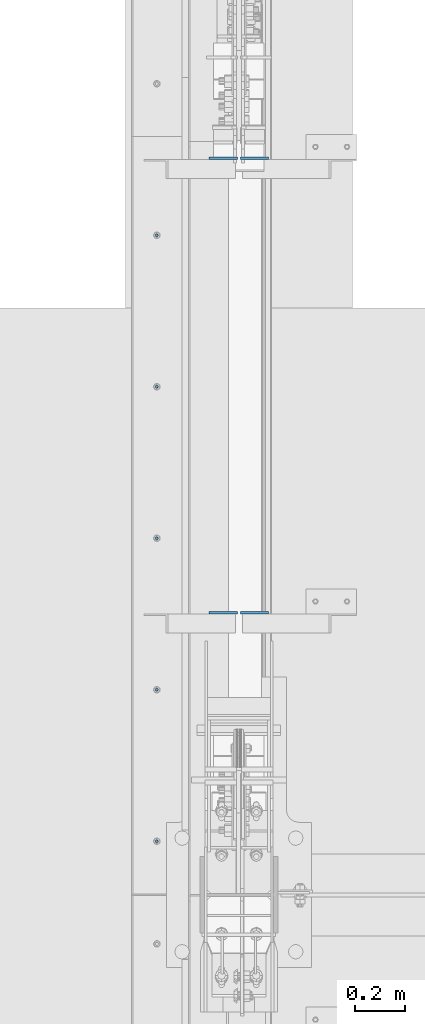
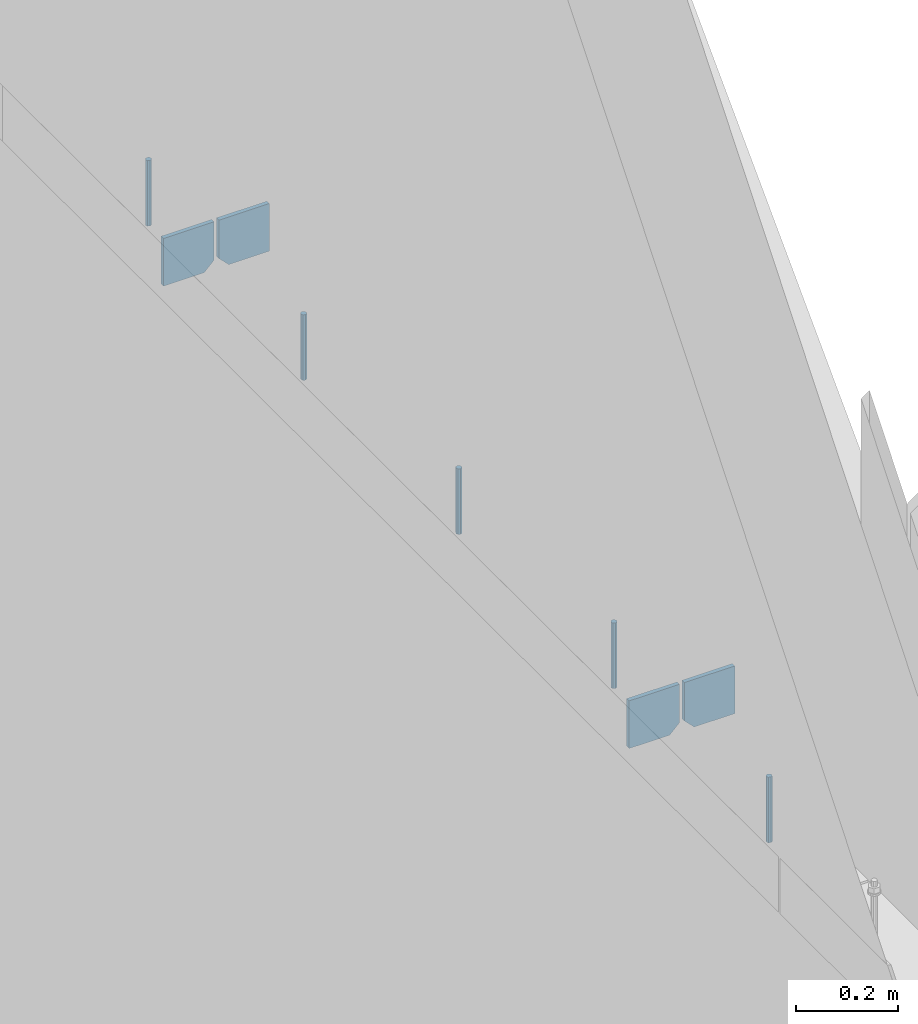
# One storey, part 390 of 1179: 9 columns, 1 element without a shape of its own.
"""IFC2X3 building model written with IfcOpenShell, lengths in millimetres."""

from ifc_helpers import new_model, si_unit, frame, origin_with_axes, place, context, subcontext, project, spatial, faceted_brep, material, type_object, element, aggregate, save


model = new_model("IFC2X3")

# Units and contexts
model_context = context("Model", 3, precision=1e-05, world=origin_with_axes())
body_context = subcontext(model_context, "Body", "Model", "MODEL_VIEW")
ifc_project = project(units=[si_unit("LENGTHUNIT", "METRE", prefix="MILLI"), si_unit("AREAUNIT", "SQUARE_METRE"), si_unit("VOLUMEUNIT", "CUBIC_METRE"), si_unit("MASSUNIT", "GRAM", prefix="KILO"), si_unit("TIMEUNIT", "SECOND"), si_unit("PLANEANGLEUNIT", "RADIAN"), si_unit("SOLIDANGLEUNIT", "STERADIAN"), si_unit("THERMODYNAMICTEMPERATUREUNIT", "DEGREE_CELSIUS"), si_unit("LUMINOUSINTENSITYUNIT", "LUMEN")], contexts=[model_context])

# Site, building, storey
site_placement = place(None, origin_with_axes())
site = spatial("IfcSite", under=ifc_project, at=site_placement, CompositionType="ELEMENT")
building_placement = place(site_placement, origin_with_axes())
building = spatial("IfcBuilding", under=site, at=building_placement, Name="Undefined", CompositionType="ELEMENT")
storey_placement = place(building_placement, origin_with_axes())
storey = spatial("IfcBuildingStorey", under=building, at=storey_placement, Name="Undefined", CompositionType="ELEMENT", Elevation=0.0)

# Assembly, columns
assembly_placement = place(storey_placement, origin_with_axes())
assembly = element("IfcElementAssembly", 1, at=assembly_placement, inside=storey, Name="BEAM", AssemblyPlace="NOTDEFINED", PredefinedType="RIGID_FRAME")
ifc_material_1 = material(Name="STEEL/A36")
column_type_1 = type_object("IfcColumnType", PredefinedType="NOTDEFINED")
column_1_placement = place(assembly_placement, frame((494.506249999998, 12615.8625, 3702.05), z_axis=(-1.0, 0.0, 0.0), x_axis=(0.0, 0.0, 1.0)))
column_1 = element("IfcColumn", 2, at=column_1_placement, type_object=column_type_1, material=ifc_material_1, Name="PLATE", context=body_context, shape_type="Brep", body=[
    faceted_brep([(22.2250000000004, 4.76250000000073, 57.1500000000015), (0.0, 4.76250000000073, 34.9249999999993), (0.0, -4.76250000000073, 34.9249999999993), (22.2250000000004, -4.76250000000073, 57.1500000000015), (114.300000000001, 4.76250000000073, 57.1500000000015), (114.300000000001, 4.76250000000073, -57.1500000000015), (0.0, 4.76250000000073, -57.1500000000015), (114.300000000001, -4.76250000000073, 57.1500000000015), (0.0, -4.76250000000073, -57.1500000000015), (114.300000000001, -4.76250000000073, -57.1500000000015)], [[[0, 1, 2, 3]], [[4, 5, 6, 1, 0]], [[7, 4, 0, 3]], [[8, 9, 7, 3, 2]], [[8, 6, 5, 9]], [[7, 9, 5, 4]], [[6, 8, 2, 1]]]),
])
column_2_placement = place(assembly_placement, frame((369.093750000003, 12615.8625, 3702.05), z_axis=(1.0, 0.0, 0.0), x_axis=(0.0, 0.0, 1.0)))
column_2 = element("IfcColumn", 3, at=column_2_placement, type_object=column_type_1, material=ifc_material_1, Name="PLATE", context=body_context, shape_type="Brep", body=[
    faceted_brep([(22.2250000000004, 4.76250000000073, 57.1500000000015), (0.0, 4.76250000000073, 34.9249999999993), (0.0, -4.76250000000073, 34.9249999999993), (22.2250000000004, -4.76250000000073, 57.1500000000015), (114.300000000001, 4.76250000000073, 57.1500000000015), (114.300000000001, 4.76250000000073, -57.1500000000015), (0.0, 4.76250000000073, -57.1500000000015), (114.300000000001, -4.76250000000073, 57.1500000000015), (0.0, -4.76250000000073, -57.1500000000015), (114.300000000001, -4.76250000000073, -57.1500000000015)], [[[0, 1, 2, 3]], [[4, 5, 6, 1, 0]], [[7, 4, 0, 3]], [[8, 9, 7, 3, 2]], [[8, 6, 5, 9]], [[7, 9, 5, 4]], [[6, 8, 2, 1]]]),
])
column_3_placement = place(assembly_placement, frame((494.506249999998, 14444.6625, 3702.05), z_axis=(-1.0, 0.0, 0.0), x_axis=(0.0, 0.0, 1.0)))
column_3 = element("IfcColumn", 4, at=column_3_placement, type_object=column_type_1, material=ifc_material_1, Name="PLATE", context=body_context, shape_type="Brep", body=[
    faceted_brep([(22.2250000000004, 4.76250000000073, 57.1500000000015), (0.0, 4.76250000000073, 34.9249999999993), (0.0, -4.76250000000073, 34.9249999999993), (22.2250000000004, -4.76250000000073, 57.1500000000015), (114.300000000001, 4.76250000000073, 57.1500000000015), (114.300000000001, 4.76250000000073, -57.1500000000015), (0.0, 4.76250000000073, -57.1500000000015), (114.300000000001, -4.76250000000073, 57.1500000000015), (0.0, -4.76250000000073, -57.1500000000015), (114.300000000001, -4.76250000000073, -57.1500000000015)], [[[0, 1, 2, 3]], [[4, 5, 6, 1, 0]], [[7, 4, 0, 3]], [[8, 9, 7, 3, 2]], [[8, 6, 5, 9]], [[7, 9, 5, 4]], [[6, 8, 2, 1]]]),
])
column_4_placement = place(assembly_placement, frame((369.093750000003, 14444.6625, 3702.05), z_axis=(1.0, 0.0, 0.0), x_axis=(0.0, 0.0, 1.0)))
column_4 = element("IfcColumn", 5, at=column_4_placement, type_object=column_type_1, material=ifc_material_1, Name="PLATE", context=body_context, shape_type="Brep", body=[
    faceted_brep([(22.2250000000004, 4.76250000000073, 57.1500000000015), (0.0, 4.76250000000073, 34.9249999999993), (0.0, -4.76250000000073, 34.9249999999993), (22.2250000000004, -4.76250000000073, 57.1500000000015), (114.300000000001, 4.76250000000073, 57.1500000000015), (114.300000000001, 4.76250000000073, -57.1500000000015), (0.0, 4.76250000000073, -57.1500000000015), (114.300000000001, -4.76250000000073, 57.1500000000015), (0.0, -4.76250000000073, -57.1500000000015), (114.300000000001, -4.76250000000073, -57.1500000000015)], [[[0, 1, 2, 3]], [[4, 5, 6, 1, 0]], [[7, 4, 0, 3]], [[8, 9, 7, 3, 2]], [[8, 6, 5, 9]], [[7, 9, 5, 4]], [[6, 8, 2, 1]]]),
])
ifc_material_2 = material(Name="STEEL/A307")
column_type_2 = type_object("IfcColumnType", PredefinedType="NOTDEFINED")
column_5_placement = place(assembly_placement, frame((101.599999999999, 14135.1, 4108.45), z_axis=(0.0, 1.0, 0.0), x_axis=(0.0, 0.0, 1.0)))
column_5 = element("IfcColumn", 6, at=column_5_placement, type_object=column_type_2, material=ifc_material_2, Name="THREADED ROD", context=body_context, shape_type="Brep", body=[
    faceted_brep([(0.0, -6.34999999999854, 0.0), (0.0, -4.49012806053361, -4.49012806053452), (157.162499999999, -4.49012806053361, -4.49012806053361), (157.162499999999, -6.34999999999854, 0.0), (0.0, 0.0, -6.34999999999991), (157.162499999999, 0.0, -6.34999999999854), (0.0, 4.49012806053361, -4.49012806053452), (157.162499999999, 4.49012806053361, -4.49012806053361), (0.0, 6.34999999999854, 0.0), (157.162499999999, 6.34999999999854, 0.0), (0.0, 4.49012806053361, 4.49012806053452), (157.162499999999, 4.49012806053361, 4.49012806053361), (0.0, 0.0, 6.34999999999991), (157.162499999999, 0.0, 6.34999999999854), (0.0, -4.49012806053361, 4.49012806053452), (157.162499999999, -4.49012806053361, 4.49012806053361)], [[[0, 1, 2, 3]], [[1, 4, 5, 2]], [[4, 6, 7, 5]], [[6, 8, 9, 7]], [[8, 10, 11, 9]], [[10, 12, 13, 11]], [[12, 14, 15, 13]], [[14, 0, 3, 15]], [[5, 7, 9, 11, 13, 15, 3, 2]], [[14, 12, 10, 8, 6, 4, 1, 0]]]),
])
column_6_placement = place(assembly_placement, frame((101.599999999999, 13525.5, 4108.45), z_axis=(0.0, 1.0, 0.0), x_axis=(0.0, 0.0, 1.0)))
column_6 = element("IfcColumn", 7, at=column_6_placement, type_object=column_type_2, material=ifc_material_2, Name="THREADED ROD", context=body_context, shape_type="Brep", body=[
    faceted_brep([(0.0, -6.34999999999854, 0.0), (0.0, -4.49012806053361, -4.49012806053452), (157.162499999999, -4.49012806053361, -4.49012806053361), (157.162499999999, -6.34999999999854, 0.0), (0.0, 0.0, -6.34999999999991), (157.162499999999, 0.0, -6.34999999999854), (0.0, 4.49012806053361, -4.49012806053452), (157.162499999999, 4.49012806053361, -4.49012806053361), (0.0, 6.34999999999854, 0.0), (157.162499999999, 6.34999999999854, 0.0), (0.0, 4.49012806053361, 4.49012806053452), (157.162499999999, 4.49012806053361, 4.49012806053361), (0.0, 0.0, 6.34999999999991), (157.162499999999, 0.0, 6.34999999999854), (0.0, -4.49012806053361, 4.49012806053452), (157.162499999999, -4.49012806053361, 4.49012806053361)], [[[0, 1, 2, 3]], [[1, 4, 5, 2]], [[4, 6, 7, 5]], [[6, 8, 9, 7]], [[8, 10, 11, 9]], [[10, 12, 13, 11]], [[12, 14, 15, 13]], [[14, 0, 3, 15]], [[5, 7, 9, 11, 13, 15, 3, 2]], [[14, 12, 10, 8, 6, 4, 1, 0]]]),
])
column_7_placement = place(assembly_placement, frame((101.599999999999, 12915.9, 4108.45), z_axis=(0.0, 1.0, 0.0), x_axis=(0.0, 0.0, 1.0)))
column_7 = element("IfcColumn", 8, at=column_7_placement, type_object=column_type_2, material=ifc_material_2, Name="THREADED ROD", context=body_context, shape_type="Brep", body=[
    faceted_brep([(0.0, -6.34999999999854, 0.0), (0.0, -4.49012806053361, -4.49012806053452), (157.162499999999, -4.49012806053361, -4.49012806053361), (157.162499999999, -6.34999999999854, 0.0), (0.0, 0.0, -6.34999999999991), (157.162499999999, 0.0, -6.34999999999854), (0.0, 4.49012806053361, -4.49012806053452), (157.162499999999, 4.49012806053361, -4.49012806053361), (0.0, 6.34999999999854, 0.0), (157.162499999999, 6.34999999999854, 0.0), (0.0, 4.49012806053361, 4.49012806053452), (157.162499999999, 4.49012806053361, 4.49012806053361), (0.0, 0.0, 6.34999999999991), (157.162499999999, 0.0, 6.34999999999854), (0.0, -4.49012806053361, 4.49012806053452), (157.162499999999, -4.49012806053361, 4.49012806053361)], [[[0, 1, 2, 3]], [[1, 4, 5, 2]], [[4, 6, 7, 5]], [[6, 8, 9, 7]], [[8, 10, 11, 9]], [[10, 12, 13, 11]], [[12, 14, 15, 13]], [[14, 0, 3, 15]], [[5, 7, 9, 11, 13, 15, 3, 2]], [[14, 12, 10, 8, 6, 4, 1, 0]]]),
])
column_8_placement = place(assembly_placement, frame((101.599999999999, 12306.3, 4108.45), z_axis=(0.0, 1.0, 0.0), x_axis=(0.0, 0.0, 1.0)))
column_8 = element("IfcColumn", 9, at=column_8_placement, type_object=column_type_2, material=ifc_material_2, Name="THREADED ROD", context=body_context, shape_type="Brep", body=[
    faceted_brep([(0.0, -6.34999999999854, 0.0), (0.0, -4.49012806053361, -4.49012806053452), (157.162499999999, -4.49012806053361, -4.49012806053361), (157.162499999999, -6.34999999999854, 0.0), (0.0, 0.0, -6.34999999999991), (157.162499999999, 0.0, -6.34999999999854), (0.0, 4.49012806053361, -4.49012806053452), (157.162499999999, 4.49012806053361, -4.49012806053361), (0.0, 6.34999999999854, 0.0), (157.162499999999, 6.34999999999854, 0.0), (0.0, 4.49012806053361, 4.49012806053452), (157.162499999999, 4.49012806053361, 4.49012806053361), (0.0, 0.0, 6.34999999999991), (157.162499999999, 0.0, 6.34999999999854), (0.0, -4.49012806053361, 4.49012806053452), (157.162499999999, -4.49012806053361, 4.49012806053361)], [[[0, 1, 2, 3]], [[1, 4, 5, 2]], [[4, 6, 7, 5]], [[6, 8, 9, 7]], [[8, 10, 11, 9]], [[10, 12, 13, 11]], [[12, 14, 15, 13]], [[14, 0, 3, 15]], [[5, 7, 9, 11, 13, 15, 3, 2]], [[14, 12, 10, 8, 6, 4, 1, 0]]]),
])
column_9_placement = place(assembly_placement, frame((101.599999999999, 11696.7, 4108.45), z_axis=(0.0, 1.0, 0.0), x_axis=(0.0, 0.0, 1.0)))
column_9 = element("IfcColumn", 10, at=column_9_placement, type_object=column_type_2, material=ifc_material_2, Name="THREADED ROD", context=body_context, shape_type="Brep", body=[
    faceted_brep([(0.0, -6.34999999999854, 0.0), (0.0, -4.49012806053361, -4.49012806053452), (157.162499999999, -4.49012806053361, -4.49012806053361), (157.162499999999, -6.34999999999854, 0.0), (0.0, 0.0, -6.34999999999991), (157.162499999999, 0.0, -6.34999999999854), (0.0, 4.49012806053361, -4.49012806053452), (157.162499999999, 4.49012806053361, -4.49012806053361), (0.0, 6.34999999999854, 0.0), (157.162499999999, 6.34999999999854, 0.0), (0.0, 4.49012806053361, 4.49012806053452), (157.162499999999, 4.49012806053361, 4.49012806053361), (0.0, 0.0, 6.34999999999991), (157.162499999999, 0.0, 6.34999999999854), (0.0, -4.49012806053361, 4.49012806053452), (157.162499999999, -4.49012806053361, 4.49012806053361)], [[[0, 1, 2, 3]], [[1, 4, 5, 2]], [[4, 6, 7, 5]], [[6, 8, 9, 7]], [[8, 10, 11, 9]], [[10, 12, 13, 11]], [[12, 14, 15, 13]], [[14, 0, 3, 15]], [[5, 7, 9, 11, 13, 15, 3, 2]], [[14, 12, 10, 8, 6, 4, 1, 0]]]),
])
aggregate(assembly, [column_5, column_6, column_7, column_8, column_9, column_1, column_2, column_3, column_4])

save(model, "model.ifc")
